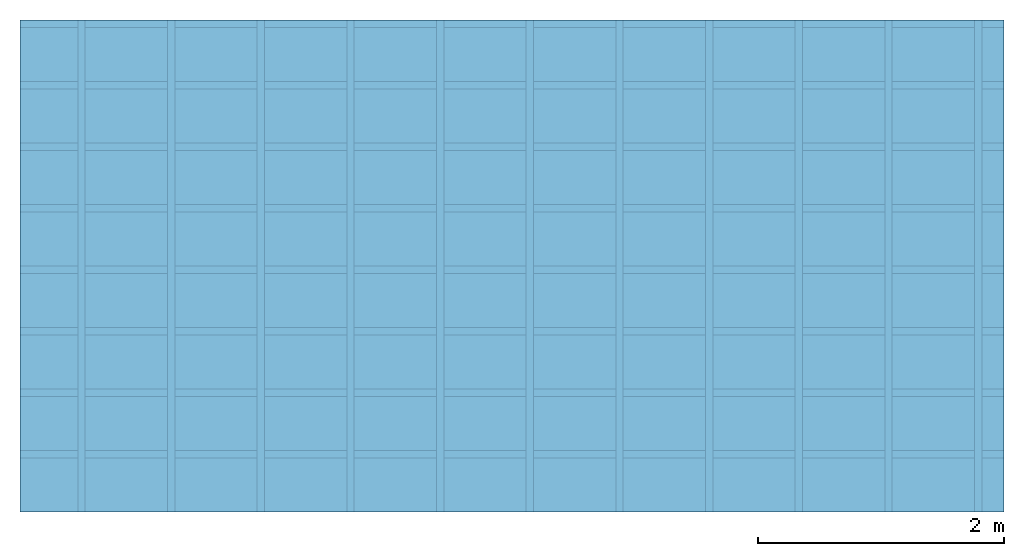
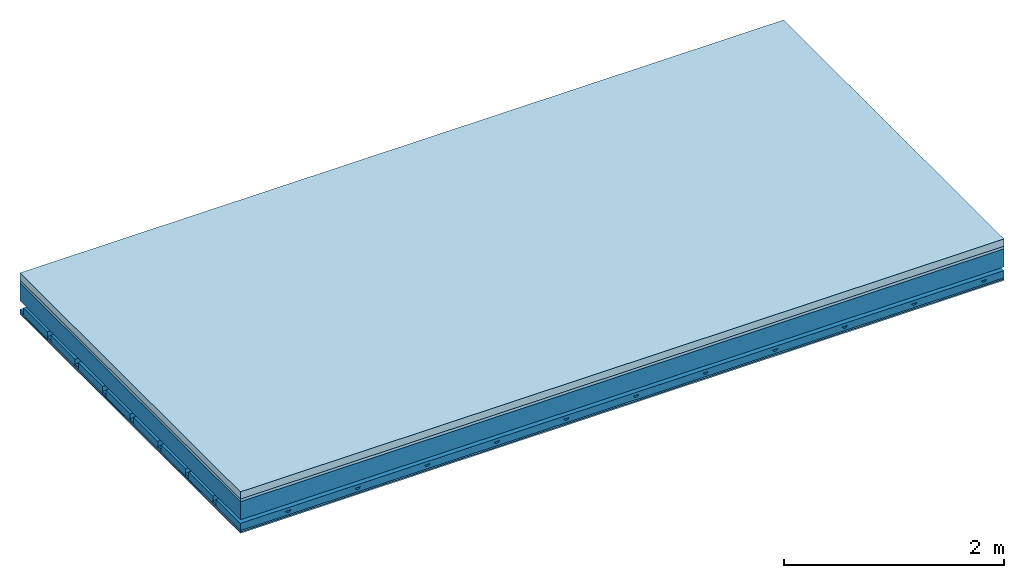
# One storey: 4 members, 4 plates, 1 element without a shape of its own.
"""IFC4 building model written with IfcOpenShell, lengths in metres."""

from ifc_helpers import new_model, si_unit, derived_unit, direction, frame, frame_2d, origin, origin_with_axes, place, context, project, spatial, polyline, rectangle, outline, extrude, material, layer, layer_set, type_object, element, aggregate, save


model = new_model("IFC4")

# Units and contexts
plan_context = context("Plan", 3, precision=1e-05, world=origin(), true_north=direction((0.0, 1.0)))
model_context = context("Model", 3, precision=1e-05, world=origin(), true_north=direction((0.0, 1.0)))
ifc_project = project(units=[si_unit("LENGTHUNIT", "METRE"), derived_unit("SOUNDPRESSUREUNIT", [(si_unit("PRESSUREUNIT", "PASCAL", prefix="MICRO"), 0)]), si_unit("ENERGYUNIT", "JOULE", prefix="MEGA"), si_unit("MASSUNIT", "GRAM", prefix="KILO"), derived_unit("THERMALTRANSMITTANCEUNIT", [(si_unit("POWERUNIT", "WATT"), 1), (si_unit("AREAUNIT", "SQUARE_METRE"), -1), (si_unit("THERMODYNAMICTEMPERATUREUNIT", "KELVIN"), -1)]), derived_unit("AREADENSITYUNIT", [(si_unit("MASSUNIT", "GRAM", prefix="KILO"), 1), (si_unit("AREAUNIT", "SQUARE_METRE"), -1)]), derived_unit("USERDEFINED", [(si_unit("ENERGYUNIT", "JOULE", prefix="MEGA"), 1), (si_unit("AREAUNIT", "SQUARE_METRE"), -1)])], contexts=[plan_context, model_context])

# Site, building, storey
site = spatial("IfcSite", under=ifc_project)
building_placement = place(None, origin())
building = spatial("IfcBuilding", under=site, at=building_placement)
storey_placement = place(building_placement, origin())
storey = spatial("IfcBuildingStorey", under=building, at=storey_placement)

# Slab, members, plates
ifc_material_1 = material(Name="Cement screed", Category="04.006")
ifc_layer_1 = layer(ifc_material_1, 0.08, Name="On-material")
ifc_material_2 = material()
ifc_layer_2 = layer(ifc_material_2, 0.03, Name="Impact sound insulation")
ifc_layer_3 = layer(None, 0.2, Name="Supporting structure")
ifc_material_3 = material(Name="no composite action")
ifc_layer_4 = layer(ifc_material_3, 0.0, Name="Bond")
ifc_layer_5 = layer(None, 0.093, Name="Coupling")
ifc_layer_6 = layer(None, 0.027, Name="Battens / profiles")
ifc_material_4 = material(Category="03.007")
ifc_layer_7 = layer(ifc_material_4, 0.015, Name="Ceiling covering 1st layer")
ifc_layer_8 = layer(ifc_material_4, 0.015, Name="Ceiling covering layer 2")
ifc_material_5 = material(Name="Glued joints")
ifc_layer_9 = layer(ifc_material_5, 0.0, Name="Surface / treatment")
ifc_layer_set = layer_set([ifc_layer_1, ifc_layer_2, ifc_layer_3, ifc_layer_4, ifc_layer_5, ifc_layer_6, ifc_layer_7, ifc_layer_8, ifc_layer_9])
slab_type = type_object("IfcSlabType", Name="A0897", PredefinedType="NOTDEFINED", material=ifc_layer_set)
slab_placement = place(None, frame((0.0, 0.0, 0.0), z_axis=(0.0, 0.0, -1.0), x_axis=(1.0, 0.0, 0.0)))
slab = element("IfcSlab", 1, at=slab_placement, inside=storey, type_object=slab_type, material=ifc_layer_set, Name="Slab #1")
ifc_material_6 = material()
member_1_placement = place(slab_placement, origin())
member_1 = element("IfcMember", 2, at=member_1_placement, material=ifc_material_6, Name="Supporting structure", context=plan_context, shape_type="SweptSolid", body=[
    extrude(rectangle(XDim=1.0, YDim=0.2, at=frame_2d((0.5, 0.1), x_axis=(1.0, 0.0))), frame((0.0, 4.0, 0.11), z_axis=(0.0, -1.0, 0.0), x_axis=(1.0, 0.0, 0.0)), (0.0, 0.0, 1.0), 4.0),
    extrude(rectangle(XDim=1.0, YDim=0.2, at=frame_2d((0.5, 0.1), x_axis=(1.0, 0.0))), frame((1.0, 4.0, 0.11), z_axis=(0.0, -1.0, 0.0), x_axis=(1.0, 0.0, 0.0)), (0.0, 0.0, 1.0), 4.0),
    extrude(rectangle(XDim=1.0, YDim=0.2, at=frame_2d((0.5, 0.1), x_axis=(1.0, 0.0))), frame((2.0, 4.0, 0.11), z_axis=(0.0, -1.0, 0.0), x_axis=(1.0, 0.0, 0.0)), (0.0, 0.0, 1.0), 4.0),
    extrude(rectangle(XDim=1.0, YDim=0.2, at=frame_2d((0.5, 0.1), x_axis=(1.0, 0.0))), frame((3.0, 4.0, 0.11), z_axis=(0.0, -1.0, 0.0), x_axis=(1.0, 0.0, 0.0)), (0.0, 0.0, 1.0), 4.0),
    extrude(rectangle(XDim=1.0, YDim=0.2, at=frame_2d((0.5, 0.1), x_axis=(1.0, 0.0))), frame((4.0, 4.0, 0.11), z_axis=(0.0, -1.0, 0.0), x_axis=(1.0, 0.0, 0.0)), (0.0, 0.0, 1.0), 4.0),
    extrude(rectangle(XDim=1.0, YDim=0.2, at=frame_2d((0.5, 0.1), x_axis=(1.0, 0.0))), frame((5.0, 4.0, 0.11), z_axis=(0.0, -1.0, 0.0), x_axis=(1.0, 0.0, 0.0)), (0.0, 0.0, 1.0), 4.0),
    extrude(rectangle(XDim=1.0, YDim=0.2, at=frame_2d((0.5, 0.1), x_axis=(1.0, 0.0))), frame((6.0, 4.0, 0.11), z_axis=(0.0, -1.0, 0.0), x_axis=(1.0, 0.0, 0.0)), (0.0, 0.0, 1.0), 4.0),
    extrude(rectangle(XDim=1.0, YDim=0.2, at=frame_2d((0.5, 0.1), x_axis=(1.0, 0.0))), frame((7.0, 4.0, 0.11), z_axis=(0.0, -1.0, 0.0), x_axis=(1.0, 0.0, 0.0)), (0.0, 0.0, 1.0), 4.0),
])
ifc_material_7 = material()
member_2_placement = place(slab_placement, origin())
member_2 = element("IfcMember", 3, at=member_2_placement, material=ifc_material_7, Name="Coupling", context=plan_context, shape_type="SweptSolid", body=[
    extrude(outline(polyline([(0.0, 0.0), (0.06, 0.0), (0.04, 0.02), (0.02, 0.02), (0.0, 0.0)])), frame((0.47, 4.0, 0.383), z_axis=(0.0, -1.0, 0.0), x_axis=(1.0, 0.0, 0.0)), (0.0, 0.0, 1.0), 4.0),
    extrude(outline(polyline([(0.0, 0.0), (0.06, 0.0), (0.04, 0.02), (0.02, 0.02), (0.0, 0.0)])), frame((1.199, 4.0, 0.383), z_axis=(0.0, -1.0, 0.0), x_axis=(1.0, 0.0, 0.0)), (0.0, 0.0, 1.0), 4.0),
    extrude(outline(polyline([(0.0, 0.0), (0.06, 0.0), (0.04, 0.02), (0.02, 0.02), (0.0, 0.0)])), frame((1.928, 4.0, 0.383), z_axis=(0.0, -1.0, 0.0), x_axis=(1.0, 0.0, 0.0)), (0.0, 0.0, 1.0), 4.0),
    extrude(outline(polyline([(0.0, 0.0), (0.06, 0.0), (0.04, 0.02), (0.02, 0.02), (0.0, 0.0)])), frame((2.657, 4.0, 0.383), z_axis=(0.0, -1.0, 0.0), x_axis=(1.0, 0.0, 0.0)), (0.0, 0.0, 1.0), 4.0),
    extrude(outline(polyline([(0.0, 0.0), (0.06, 0.0), (0.04, 0.02), (0.02, 0.02), (0.0, 0.0)])), frame((3.386, 4.0, 0.383), z_axis=(0.0, -1.0, 0.0), x_axis=(1.0, 0.0, 0.0)), (0.0, 0.0, 1.0), 4.0),
    extrude(outline(polyline([(0.0, 0.0), (0.06, 0.0), (0.04, 0.02), (0.02, 0.02), (0.0, 0.0)])), frame((4.115, 4.0, 0.383), z_axis=(0.0, -1.0, 0.0), x_axis=(1.0, 0.0, 0.0)), (0.0, 0.0, 1.0), 4.0),
    extrude(outline(polyline([(0.0, 0.0), (0.06, 0.0), (0.04, 0.02), (0.02, 0.02), (0.0, 0.0)])), frame((4.844, 4.0, 0.383), z_axis=(0.0, -1.0, 0.0), x_axis=(1.0, 0.0, 0.0)), (0.0, 0.0, 1.0), 4.0),
    extrude(outline(polyline([(0.0, 0.0), (0.06, 0.0), (0.04, 0.02), (0.02, 0.02), (0.0, 0.0)])), frame((5.573, 4.0, 0.383), z_axis=(0.0, -1.0, 0.0), x_axis=(1.0, 0.0, 0.0)), (0.0, 0.0, 1.0), 4.0),
    extrude(outline(polyline([(0.0, 0.0), (0.06, 0.0), (0.04, 0.02), (0.02, 0.02), (0.0, 0.0)])), frame((6.302, 4.0, 0.383), z_axis=(0.0, -1.0, 0.0), x_axis=(1.0, 0.0, 0.0)), (0.0, 0.0, 1.0), 4.0),
    extrude(outline(polyline([(0.0, 0.0), (0.06, 0.0), (0.04, 0.02), (0.02, 0.02), (0.0, 0.0)])), frame((7.031, 4.0, 0.383), z_axis=(0.0, -1.0, 0.0), x_axis=(1.0, 0.0, 0.0)), (0.0, 0.0, 1.0), 4.0),
    extrude(outline(polyline([(0.0, 0.0), (0.06, 0.0), (0.04, 0.02), (0.02, 0.02), (0.0, 0.0)])), frame((7.76, 4.0, 0.383), z_axis=(0.0, -1.0, 0.0), x_axis=(1.0, 0.0, 0.0)), (0.0, 0.0, 1.0), 4.0),
])
ifc_material_8 = material()
member_3_placement = place(slab_placement, origin())
member_3 = element("IfcMember", 4, at=member_3_placement, material=ifc_material_8, Name="Battens / profiles", context=plan_context, shape_type="SweptSolid", body=[
    extrude(rectangle(XDim=0.06, YDim=0.027, at=frame_2d((0.03, 0.0135), x_axis=(1.0, 0.0))), frame((0.0, 0.0, 0.403), z_axis=(1.0, 0.0, 0.0), x_axis=(0.0, 1.0, 0.0)), (0.0, 0.0, 1.0), 8.0),
    extrude(rectangle(XDim=0.06, YDim=0.027, at=frame_2d((0.03, 0.0135), x_axis=(1.0, 0.0))), frame((0.0, 0.5, 0.403), z_axis=(1.0, 0.0, 0.0), x_axis=(0.0, 1.0, 0.0)), (0.0, 0.0, 1.0), 8.0),
    extrude(rectangle(XDim=0.06, YDim=0.027, at=frame_2d((0.03, 0.0135), x_axis=(1.0, 0.0))), frame((0.0, 1.0, 0.403), z_axis=(1.0, 0.0, 0.0), x_axis=(0.0, 1.0, 0.0)), (0.0, 0.0, 1.0), 8.0),
    extrude(rectangle(XDim=0.06, YDim=0.027, at=frame_2d((0.03, 0.0135), x_axis=(1.0, 0.0))), frame((0.0, 1.5, 0.403), z_axis=(1.0, 0.0, 0.0), x_axis=(0.0, 1.0, 0.0)), (0.0, 0.0, 1.0), 8.0),
    extrude(rectangle(XDim=0.06, YDim=0.027, at=frame_2d((0.03, 0.0135), x_axis=(1.0, 0.0))), frame((0.0, 2.0, 0.403), z_axis=(1.0, 0.0, 0.0), x_axis=(0.0, 1.0, 0.0)), (0.0, 0.0, 1.0), 8.0),
    extrude(rectangle(XDim=0.06, YDim=0.027, at=frame_2d((0.03, 0.0135), x_axis=(1.0, 0.0))), frame((0.0, 2.5, 0.403), z_axis=(1.0, 0.0, 0.0), x_axis=(0.0, 1.0, 0.0)), (0.0, 0.0, 1.0), 8.0),
    extrude(rectangle(XDim=0.06, YDim=0.027, at=frame_2d((0.03, 0.0135), x_axis=(1.0, 0.0))), frame((0.0, 3.0, 0.403), z_axis=(1.0, 0.0, 0.0), x_axis=(0.0, 1.0, 0.0)), (0.0, 0.0, 1.0), 8.0),
    extrude(rectangle(XDim=0.06, YDim=0.027, at=frame_2d((0.03, 0.0135), x_axis=(1.0, 0.0))), frame((0.0, 3.5, 0.403), z_axis=(1.0, 0.0, 0.0), x_axis=(0.0, 1.0, 0.0)), (0.0, 0.0, 1.0), 8.0),
])
ifc_material_9 = material()
member_4_placement = place(slab_placement, origin())
member_4 = element("IfcMember", 5, at=member_4_placement, material=ifc_material_9, Name="Cavity", context=plan_context, shape_type="SweptSolid", body=[
    extrude(rectangle(XDim=0.44, YDim=0.08, at=frame_2d((0.22, 0.04), x_axis=(1.0, 0.0))), frame((0.0, 0.06, 0.35), z_axis=(1.0, 0.0, 0.0), x_axis=(0.0, 1.0, 0.0)), (0.0, 0.0, 1.0), 8.0),
    extrude(rectangle(XDim=0.44, YDim=0.08, at=frame_2d((0.22, 0.04), x_axis=(1.0, 0.0))), frame((0.0, 0.56, 0.35), z_axis=(1.0, 0.0, 0.0), x_axis=(0.0, 1.0, 0.0)), (0.0, 0.0, 1.0), 8.0),
    extrude(rectangle(XDim=0.44, YDim=0.08, at=frame_2d((0.22, 0.04), x_axis=(1.0, 0.0))), frame((0.0, 1.06, 0.35), z_axis=(1.0, 0.0, 0.0), x_axis=(0.0, 1.0, 0.0)), (0.0, 0.0, 1.0), 8.0),
    extrude(rectangle(XDim=0.44, YDim=0.08, at=frame_2d((0.22, 0.04), x_axis=(1.0, 0.0))), frame((0.0, 1.56, 0.35), z_axis=(1.0, 0.0, 0.0), x_axis=(0.0, 1.0, 0.0)), (0.0, 0.0, 1.0), 8.0),
    extrude(rectangle(XDim=0.44, YDim=0.08, at=frame_2d((0.22, 0.04), x_axis=(1.0, 0.0))), frame((0.0, 2.06, 0.35), z_axis=(1.0, 0.0, 0.0), x_axis=(0.0, 1.0, 0.0)), (0.0, 0.0, 1.0), 8.0),
    extrude(rectangle(XDim=0.44, YDim=0.08, at=frame_2d((0.22, 0.04), x_axis=(1.0, 0.0))), frame((0.0, 2.56, 0.35), z_axis=(1.0, 0.0, 0.0), x_axis=(0.0, 1.0, 0.0)), (0.0, 0.0, 1.0), 8.0),
    extrude(rectangle(XDim=0.44, YDim=0.08, at=frame_2d((0.22, 0.04), x_axis=(1.0, 0.0))), frame((0.0, 3.06, 0.35), z_axis=(1.0, 0.0, 0.0), x_axis=(0.0, 1.0, 0.0)), (0.0, 0.0, 1.0), 8.0),
    extrude(rectangle(XDim=0.44, YDim=0.08, at=frame_2d((0.22, 0.04), x_axis=(1.0, 0.0))), frame((0.0, 3.56, 0.35), z_axis=(1.0, 0.0, 0.0), x_axis=(0.0, 1.0, 0.0)), (0.0, 0.0, 1.0), 8.0),
])
plate_1_placement = place(slab_placement, origin())
plate_1 = element("IfcPlate", 6, at=plate_1_placement, material=ifc_material_1, Name="On-material", context=plan_context, shape_type="SweptSolid", body=[
    extrude(rectangle(XDim=8.0, YDim=4.0, at=frame_2d((4.0, 2.0), x_axis=(1.0, 0.0))), origin_with_axes(), (0.0, 0.0, 1.0), 0.08),
])
plate_2_placement = place(slab_placement, origin())
plate_2 = element("IfcPlate", 7, at=plate_2_placement, material=ifc_material_2, Name="Impact sound insulation", context=plan_context, shape_type="SweptSolid", body=[
    extrude(rectangle(XDim=8.0, YDim=4.0, at=frame_2d((4.0, 2.0), x_axis=(1.0, 0.0))), frame((0.0, 0.0, 0.08), z_axis=(0.0, 0.0, 1.0), x_axis=(1.0, 0.0, 0.0)), (0.0, 0.0, 1.0), 0.03),
])
plate_3_placement = place(slab_placement, origin())
plate_3 = element("IfcPlate", 8, at=plate_3_placement, material=ifc_material_4, Name="Ceiling covering 1st layer", context=plan_context, shape_type="SweptSolid", body=[
    extrude(rectangle(XDim=8.0, YDim=4.0, at=frame_2d((4.0, 2.0), x_axis=(1.0, 0.0))), frame((0.0, 0.0, 0.43), z_axis=(0.0, 0.0, 1.0), x_axis=(1.0, 0.0, 0.0)), (0.0, 0.0, 1.0), 0.015),
])
plate_4_placement = place(slab_placement, origin())
plate_4 = element("IfcPlate", 9, at=plate_4_placement, material=ifc_material_4, Name="Ceiling covering layer 2", context=plan_context, shape_type="SweptSolid", body=[
    extrude(rectangle(XDim=8.0, YDim=4.0, at=frame_2d((4.0, 2.0), x_axis=(1.0, 0.0))), frame((0.0, 0.0, 0.445), z_axis=(0.0, 0.0, 1.0), x_axis=(1.0, 0.0, 0.0)), (0.0, 0.0, 1.0), 0.015),
])
aggregate(slab, [plate_1, plate_2, member_1, member_2, member_3, member_4, plate_3, plate_4])

save(model, "model.ifc")
